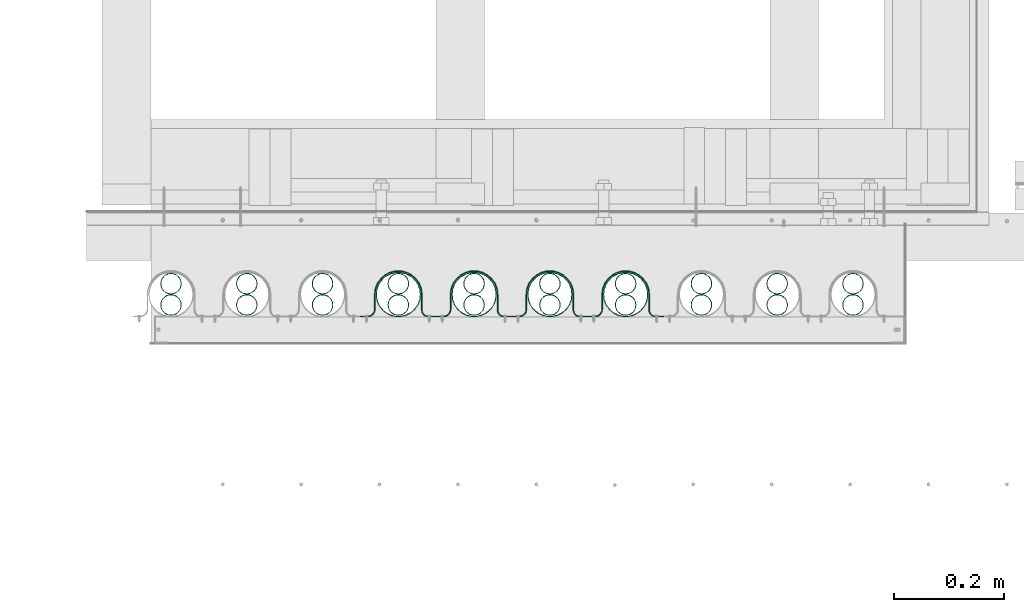
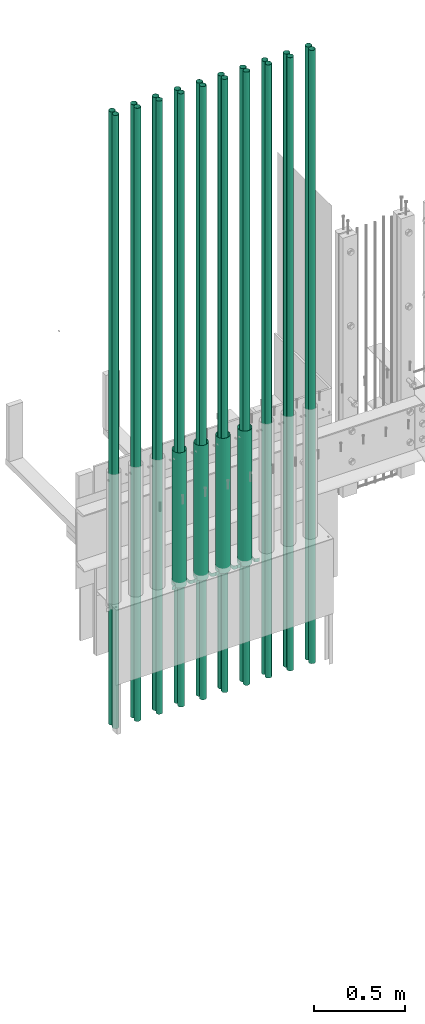
# One storey, part 6 of 44: 14 pipe fittings, 4 valves.
"""IFC4 building model written with IfcOpenShell, lengths in feet."""

from ifc_helpers import new_model, entity, si_unit, converted_unit, derived_unit, direction, frame, frame_2d, origin, origin_2d_with_axis, place, context, subcontext, project, spatial, polyline, circle_curve, parameter, trimmed, segment, composite_curve, hollow_circle, outline, extrude, source, transform, mapped, material, type_object, type_shapes, element, save


model = new_model("IFC4")

# Units and contexts
model_context = context("Model", 3, precision=0.0001, world=origin(), true_north=direction((6.12303176911189e-17, 1.0)))
body_context = subcontext(model_context, "Body", "Model", "MODEL_VIEW")
ifc_project = project(units=[converted_unit("LENGTHUNIT", "FOOT", entity("IfcRatioMeasure", 0.3048), si_unit("LENGTHUNIT", "METRE"), dimensions=[1, 0, 0, 0, 0, 0, 0]), converted_unit("AREAUNIT", "SQUARE FOOT", entity("IfcRatioMeasure", 0.09290304), si_unit("AREAUNIT", "SQUARE_METRE"), dimensions=[2, 0, 0, 0, 0, 0, 0]), converted_unit("VOLUMEUNIT", "CUBIC FOOT", entity("IfcRatioMeasure", 0.028316846592), si_unit("VOLUMEUNIT", "CUBIC_METRE"), dimensions=[3, 0, 0, 0, 0, 0, 0]), converted_unit("PLANEANGLEUNIT", "DEGREE", entity("IfcRatioMeasure", 0.0174532925199433), si_unit("PLANEANGLEUNIT", "RADIAN"), dimensions=[0, 0, 0, 0, 0, 0, 0]), si_unit("MASSUNIT", "GRAM", prefix="KILO"), derived_unit("MASSDENSITYUNIT", [(si_unit("MASSUNIT", "GRAM", prefix="KILO"), 1), (si_unit("LENGTHUNIT", "METRE"), -3)]), derived_unit("MOMENTOFINERTIAUNIT", [(si_unit("LENGTHUNIT", "METRE"), 4)]), si_unit("TIMEUNIT", "SECOND"), si_unit("FREQUENCYUNIT", "HERTZ"), si_unit("THERMODYNAMICTEMPERATUREUNIT", "DEGREE_CELSIUS"), derived_unit("THERMALTRANSMITTANCEUNIT", [(si_unit("MASSUNIT", "GRAM", prefix="KILO"), 1), (si_unit("THERMODYNAMICTEMPERATUREUNIT", "KELVIN"), -1), (si_unit("TIMEUNIT", "SECOND"), -3)]), derived_unit("VOLUMETRICFLOWRATEUNIT", [(si_unit("LENGTHUNIT", "METRE"), 3), (si_unit("TIMEUNIT", "SECOND"), -1)]), si_unit("ELECTRICCURRENTUNIT", "AMPERE"), si_unit("ELECTRICVOLTAGEUNIT", "VOLT"), si_unit("POWERUNIT", "WATT"), si_unit("FORCEUNIT", "NEWTON"), si_unit("ILLUMINANCEUNIT", "LUX"), si_unit("LUMINOUSFLUXUNIT", "LUMEN"), si_unit("LUMINOUSINTENSITYUNIT", "CANDELA"), derived_unit("USERDEFINED", [(si_unit("MASSUNIT", "GRAM", prefix="KILO"), -1), (si_unit("LENGTHUNIT", "METRE"), -2), (si_unit("TIMEUNIT", "SECOND"), 3), (si_unit("LUMINOUSFLUXUNIT", "LUMEN"), 1)]), derived_unit("LINEARVELOCITYUNIT", [(si_unit("LENGTHUNIT", "METRE"), 1), (si_unit("TIMEUNIT", "SECOND"), -1)]), si_unit("PRESSUREUNIT", "PASCAL"), derived_unit("USERDEFINED", [(si_unit("LENGTHUNIT", "METRE"), -2), (si_unit("MASSUNIT", "GRAM", prefix="KILO"), 1), (si_unit("TIMEUNIT", "SECOND"), -2)]), derived_unit("LINEARFORCEUNIT", [(si_unit("MASSUNIT", "GRAM", prefix="KILO"), 1), (si_unit("LENGTHUNIT", "METRE"), 1), (si_unit("TIMEUNIT", "SECOND"), -2), (si_unit("LENGTHUNIT", "METRE"), -1)]), derived_unit("PLANARFORCEUNIT", [(si_unit("MASSUNIT", "GRAM", prefix="KILO"), 1), (si_unit("LENGTHUNIT", "METRE"), 1), (si_unit("TIMEUNIT", "SECOND"), -2), (si_unit("LENGTHUNIT", "METRE"), -2)])], contexts=[model_context])

# Site, building, storey
site_placement = place(None, origin())
site = spatial("IfcSite", under=ifc_project, at=site_placement, CompositionType="ELEMENT")
building_placement = place(site_placement, origin())
building = spatial("IfcBuilding", under=site, at=building_placement, CompositionType="ELEMENT")
storey_placement = place(building_placement, origin())
storey = spatial("IfcBuildingStorey", under=building, at=storey_placement, CompositionType="ELEMENT", Elevation=0.0)

# Pipe fittings
ifc_material_1 = material(Name="MINI SPLIT LINE SETS", Category="Materials")
pipe_fitting_type_1 = type_object("IfcPipeFittingType", Name="Pipe:Pipe", PredefinedType="NOTDEFINED", material=ifc_material_1)
shared_shape_1 = source(origin(), body_context, "Body", "SweptSolid", [
    extrude(hollow_circle(Radius=0.0625, WallThickness=0.00260416666666666, at=origin_2d_with_axis()), frame((0.0677338327950565, 0.195337999461667, 0.0)), (0.0, 0.0, 1.0), 13.4850384539234),
    extrude(hollow_circle(Radius=0.0625, WallThickness=0.00260416666666666, at=origin_2d_with_axis()), frame((0.0677338327950565, 0.0677338327949997, 0.0)), (0.0, 0.0, 1.0), 13.4850384539234),
])
type_shapes(pipe_fitting_type_1, [shared_shape_1])
pipe_fitting_1_placement = place(storey_placement, frame((1491.01565957711, 4.12033855704859, 5.26036370303956)))
element("IfcPipeFitting", 1, at=pipe_fitting_1_placement, inside=storey, type_object=pipe_fitting_type_1, material=ifc_material_1, Name="Pipe:Pipe", ObjectType="Pipe:Pipe", PredefinedType="NOTDEFINED", context=body_context, shape_type="MappedRepresentation", body=[
    mapped(shared_shape_1, transform((0.0, 0.0, 0.0), scale=1.0)),
])
pipe_fitting_type_2 = type_object("IfcPipeFittingType", Name="Pipe2:Pipe", PredefinedType="NOTDEFINED", material=ifc_material_1)
shared_shape_2 = source(origin(), body_context, "Body", "SweptSolid", [
    extrude(hollow_circle(Radius=0.0625, WallThickness=0.00260416666666666, at=origin_2d_with_axis()), frame((0.0677338327950565, 0.195337999461667, 0.0)), (0.0, 0.0, 1.0), 13.4850384539234),
    extrude(hollow_circle(Radius=0.0625, WallThickness=0.00260416666666666, at=origin_2d_with_axis()), frame((0.0677338327950565, 0.0677338327949997, 0.0)), (0.0, 0.0, 1.0), 13.4850384539234),
])
type_shapes(pipe_fitting_type_2, [shared_shape_2])
pipe_fitting_2_placement = place(storey_placement, frame((1491.46955171939, 4.12033855704859, 5.26036370303956)))
element("IfcPipeFitting", 2, at=pipe_fitting_2_placement, inside=storey, type_object=pipe_fitting_type_2, material=ifc_material_1, Name="Pipe2:Pipe", ObjectType="Pipe2:Pipe", PredefinedType="NOTDEFINED", context=body_context, shape_type="MappedRepresentation", body=[
    mapped(shared_shape_2, transform((0.0, 0.0, 0.0), scale=1.0)),
])
pipe_fitting_type_3 = type_object("IfcPipeFittingType", Name="Pipe4:Pipe", PredefinedType="NOTDEFINED", material=ifc_material_1)
shared_shape_3 = source(origin(), body_context, "Body", "SweptSolid", [
    extrude(hollow_circle(Radius=0.0625, WallThickness=0.00260416666666666, at=origin_2d_with_axis()), frame((0.0677338327950565, 0.195337999461667, 0.0)), (0.0, 0.0, 1.0), 13.4850384539234),
    extrude(hollow_circle(Radius=0.0625, WallThickness=0.00260416666666666, at=origin_2d_with_axis()), frame((0.0677338327950565, 0.0677338327949997, 0.0)), (0.0, 0.0, 1.0), 13.4850384539234),
])
type_shapes(pipe_fitting_type_3, [shared_shape_3])
pipe_fitting_3_placement = place(storey_placement, frame((1490.56176743483, 4.1203385570486, 5.26036370303955)))
element("IfcPipeFitting", 3, at=pipe_fitting_3_placement, inside=storey, type_object=pipe_fitting_type_3, material=ifc_material_1, Name="Pipe4:Pipe", ObjectType="Pipe4:Pipe", PredefinedType="NOTDEFINED", context=body_context, shape_type="MappedRepresentation", body=[
    mapped(shared_shape_3, transform((0.0, 0.0, 0.0), scale=1.0)),
])
pipe_fitting_type_4 = type_object("IfcPipeFittingType", Name="Pipe6:Pipe", PredefinedType="NOTDEFINED", material=ifc_material_1)
shared_shape_4 = source(origin(), body_context, "Body", "SweptSolid", [
    extrude(hollow_circle(Radius=0.0625, WallThickness=0.00260416666666666, at=origin_2d_with_axis()), frame((0.0677338327950565, 0.195337999461667, 0.0)), (0.0, 0.0, 1.0), 13.4850384539234),
    extrude(hollow_circle(Radius=0.0625, WallThickness=0.00260416666666666, at=origin_2d_with_axis()), frame((0.0677338327950565, 0.0677338327949997, 0.0)), (0.0, 0.0, 1.0), 13.4850384539234),
])
type_shapes(pipe_fitting_type_4, [shared_shape_4])
pipe_fitting_4_placement = place(storey_placement, frame((1490.10787529256, 4.1203385570486, 5.26036370303955)))
element("IfcPipeFitting", 4, at=pipe_fitting_4_placement, inside=storey, type_object=pipe_fitting_type_4, material=ifc_material_1, Name="Pipe6:Pipe", ObjectType="Pipe6:Pipe", PredefinedType="NOTDEFINED", context=body_context, shape_type="MappedRepresentation", body=[
    mapped(shared_shape_4, transform((0.0, 0.0, 0.0), scale=1.0)),
])
ifc_material_2 = material(Name="GALV. PIPE", Category="Materials")
pipe_fitting_type_5 = type_object("IfcPipeFittingType", Name="Pipe7:Pipe", PredefinedType="NOTDEFINED", material=ifc_material_2)
shared_shape_5 = source(origin(), body_context, "Body", "SweptSolid", [
    extrude(hollow_circle(Radius=0.133196488133789, WallThickness=0.00260416666666666, at=frame_2d((2.91529109135044e-30, -8.88178419700125e-16), x_axis=(1.0, 0.0))), frame((0.138430320928819, 0.138430320928789, 0.0)), (0.0, 0.0, 1.0), 2.97420597925747),
])
type_shapes(pipe_fitting_type_5, [shared_shape_5])
pipe_fitting_5_placement = place(storey_placement, frame((1490.03717880442, 4.11247536199349, 7.88838525934748)))
element("IfcPipeFitting", 5, at=pipe_fitting_5_placement, inside=storey, type_object=pipe_fitting_type_5, material=ifc_material_2, Name="Pipe7:Pipe", ObjectType="Pipe7:Pipe", PredefinedType="NOTDEFINED", context=body_context, shape_type="MappedRepresentation", body=[
    mapped(shared_shape_5, transform((0.0, 0.0, 0.0), scale=1.0)),
])

# Valve
ifc_material_3 = material(Name="GALV. U BRACKET AT GALV. PIPE", Category="Materials")
valve_type_1 = type_object("IfcValveType", Name="U BRACKET8:U BRACKET", PredefinedType="NOTDEFINED", material=ifc_material_3)
shared_shape_6 = source(origin(), body_context, "Body", "SweptSolid", [
    extrude(outline(composite_curve([segment(polyline([(0.0407648216664178, -0.226295029472567), (0.0459731549997509, -0.226295029472567)]), True, "CONTINUOUS"), segment(polyline([(0.0459731549997509, -0.226295029472567), (0.0459731549997509, -0.184628362805825)]), True, "CONTINUOUS"), segment(trimmed(circle_curve(frame_2d((-0.000901845000249146, -0.184628362805825), x_axis=(0.0, 1.0)), 0.046875), [parameter(270.0)], [parameter(2.03555499613665e-13)], True, "PARAMETER"), True, "CONTINUOUS"), segment(polyline([(-0.000901845000249146, -0.137753362805825), (-0.0884402983327055, -0.137753362805825)]), True, "CONTINUOUS"), segment(trimmed(circle_curve(frame_2d((-0.0884402983327037, 0.000651041666515084), x_axis=(0.0, 1.0)), 0.138404404472415), [parameter(2.03555499613665e-13)], [parameter(180.0)], True, "PARAMETER"), False, "CONTINUOUS"), segment(polyline([(-0.0884402983327037, 0.139055446138855), (0.00430648833316294, 0.139055446138855)]), True, "CONTINUOUS"), segment(trimmed(circle_curve(frame_2d((0.00430648833316294, 0.180722112805597), x_axis=(0.0, 1.0)), 0.0416666666666667), [parameter(180.0)], [parameter(270.0)], True, "PARAMETER"), True, "CONTINUOUS"), segment(polyline([(0.0459731549998299, 0.180722112805597), (0.0459731549998308, 0.227597112805597)]), True, "CONTINUOUS"), segment(polyline([(0.0459731549998308, 0.227597112805597), (0.0407648216664969, 0.227597112805597)]), True, "CONTINUOUS"), segment(polyline([(0.0407648216664969, 0.227597112805597), (0.0407648216664969, 0.180722112805597)]), True, "CONTINUOUS"), segment(trimmed(circle_curve(frame_2d((0.00430648833316294, 0.180722112805597), x_axis=(0.0, 1.0)), 0.0364583333333333), [parameter(180.0)], [parameter(270.0)], True, "PARAMETER"), False, "CONTINUOUS"), segment(polyline([(0.00430648833316294, 0.14426377947234), (-0.0884402983327028, 0.14426377947234)]), True, "CONTINUOUS"), segment(trimmed(circle_curve(frame_2d((-0.0884402983327037, 0.000651041666515084), x_axis=(0.0, 1.0)), 0.143612737805749), [parameter(360.0)], [parameter(180.0)], True, "PARAMETER"), True, "CONTINUOUS"), segment(polyline([(-0.0884402983327055, -0.142961696139309), (-0.000901845000249146, -0.142961696139309)]), True, "CONTINUOUS"), segment(trimmed(circle_curve(frame_2d((-0.000901845000249146, -0.184628362805825), x_axis=(0.0, 1.0)), 0.0416666666666667), [parameter(270.0)], [parameter(2.03555499613665e-13)], True, "PARAMETER"), False, "CONTINUOUS"), segment(polyline([(0.0407648216664178, -0.184628362805825), (0.0407648216664178, -0.226295029472567)]), True, "CONTINUOUS")], self_intersect=False)), frame((0.226295029472567, 0.0512069877948296, 0.0), z_axis=(0.0, 0.0, 1.0), x_axis=(0.0, -1.0, 0.0)), (0.0, 0.0, 1.0), 0.078003864882298),
])
type_shapes(valve_type_1, [shared_shape_6])
valve_1_placement = place(storey_placement, frame((1489.94866305421, 4.11092510371607, 7.91059739384998)))
element("IfcValve", 6, at=valve_1_placement, inside=storey, type_object=valve_type_1, material=ifc_material_3, Name="U BRACKET8:U BRACKET", ObjectType="U BRACKET8:U BRACKET", PredefinedType="NOTDEFINED", context=body_context, shape_type="MappedRepresentation", body=[
    mapped(shared_shape_6, transform((0.0, 0.0, 0.0), scale=1.0)),
])

# Pipe fittings
pipe_fitting_type_6 = type_object("IfcPipeFittingType", Name="Pipe8:Pipe", PredefinedType="NOTDEFINED", material=ifc_material_1)
shared_shape_7 = source(origin(), body_context, "Body", "SweptSolid", [
    extrude(hollow_circle(Radius=0.0625, WallThickness=0.00260416666666666, at=origin_2d_with_axis()), frame((0.0677338327950565, 0.195337999461667, 0.0)), (0.0, 0.0, 1.0), 13.4850384539234),
    extrude(hollow_circle(Radius=0.0625, WallThickness=0.00260416666666666, at=origin_2d_with_axis()), frame((0.0677338327950565, 0.0677338327949997, 0.0)), (0.0, 0.0, 1.0), 13.4850384539234),
])
type_shapes(pipe_fitting_type_6, [shared_shape_7])
pipe_fitting_6_placement = place(storey_placement, frame((1489.65398315028, 4.1203385570486, 5.26036370303955)))
element("IfcPipeFitting", 7, at=pipe_fitting_6_placement, inside=storey, type_object=pipe_fitting_type_6, material=ifc_material_1, Name="Pipe8:Pipe", ObjectType="Pipe8:Pipe", PredefinedType="NOTDEFINED", context=body_context, shape_type="MappedRepresentation", body=[
    mapped(shared_shape_7, transform((0.0, 0.0, 0.0), scale=1.0)),
])
pipe_fitting_type_7 = type_object("IfcPipeFittingType", Name="Pipe9:Pipe", PredefinedType="NOTDEFINED", material=ifc_material_2)
shared_shape_8 = source(origin(), body_context, "Body", "SweptSolid", [
    extrude(hollow_circle(Radius=0.133196488133789, WallThickness=0.00260416666666666, at=frame_2d((2.91529109135044e-30, -8.88178419700125e-16), x_axis=(1.0, 0.0))), frame((0.138430320928819, 0.138430320928789, 0.0)), (0.0, 0.0, 1.0), 2.97420597925747),
])
type_shapes(pipe_fitting_type_7, [shared_shape_8])
pipe_fitting_7_placement = place(storey_placement, frame((1489.58328666214, 4.11247536199349, 7.88838525934748)))
element("IfcPipeFitting", 8, at=pipe_fitting_7_placement, inside=storey, type_object=pipe_fitting_type_7, material=ifc_material_2, Name="Pipe9:Pipe", ObjectType="Pipe9:Pipe", PredefinedType="NOTDEFINED", context=body_context, shape_type="MappedRepresentation", body=[
    mapped(shared_shape_8, transform((0.0, 0.0, 0.0), scale=1.0)),
])

# Valve
valve_type_2 = type_object("IfcValveType", Name="U BRACKET10:U BRACKET", PredefinedType="NOTDEFINED", material=ifc_material_3)
shared_shape_9 = source(origin(), body_context, "Body", "SweptSolid", [
    extrude(outline(composite_curve([segment(polyline([(0.0407648216664178, -0.226295029472567), (0.0459731549997509, -0.226295029472567)]), True, "CONTINUOUS"), segment(polyline([(0.0459731549997509, -0.226295029472567), (0.0459731549997509, -0.184628362805825)]), True, "CONTINUOUS"), segment(trimmed(circle_curve(frame_2d((-0.000901845000249146, -0.184628362805825), x_axis=(0.0, 1.0)), 0.046875), [parameter(270.0)], [parameter(2.03555499613665e-13)], True, "PARAMETER"), True, "CONTINUOUS"), segment(polyline([(-0.000901845000249146, -0.137753362805825), (-0.0884402983327055, -0.137753362805825)]), True, "CONTINUOUS"), segment(trimmed(circle_curve(frame_2d((-0.0884402983327037, 0.000651041666515084), x_axis=(0.0, 1.0)), 0.138404404472415), [parameter(2.03555499613665e-13)], [parameter(180.0)], True, "PARAMETER"), False, "CONTINUOUS"), segment(polyline([(-0.0884402983327037, 0.139055446138855), (0.00430648833316294, 0.139055446138855)]), True, "CONTINUOUS"), segment(trimmed(circle_curve(frame_2d((0.00430648833316294, 0.180722112805597), x_axis=(0.0, 1.0)), 0.0416666666666667), [parameter(180.0)], [parameter(270.0)], True, "PARAMETER"), True, "CONTINUOUS"), segment(polyline([(0.0459731549998299, 0.180722112805597), (0.0459731549998308, 0.227597112805597)]), True, "CONTINUOUS"), segment(polyline([(0.0459731549998308, 0.227597112805597), (0.0407648216664969, 0.227597112805597)]), True, "CONTINUOUS"), segment(polyline([(0.0407648216664969, 0.227597112805597), (0.0407648216664969, 0.180722112805597)]), True, "CONTINUOUS"), segment(trimmed(circle_curve(frame_2d((0.00430648833316294, 0.180722112805597), x_axis=(0.0, 1.0)), 0.0364583333333333), [parameter(180.0)], [parameter(270.0)], True, "PARAMETER"), False, "CONTINUOUS"), segment(polyline([(0.00430648833316294, 0.14426377947234), (-0.0884402983327028, 0.14426377947234)]), True, "CONTINUOUS"), segment(trimmed(circle_curve(frame_2d((-0.0884402983327037, 0.000651041666515084), x_axis=(0.0, 1.0)), 0.143612737805749), [parameter(360.0)], [parameter(180.0)], True, "PARAMETER"), True, "CONTINUOUS"), segment(polyline([(-0.0884402983327055, -0.142961696139309), (-0.000901845000249146, -0.142961696139309)]), True, "CONTINUOUS"), segment(trimmed(circle_curve(frame_2d((-0.000901845000249146, -0.184628362805825), x_axis=(0.0, 1.0)), 0.0416666666666667), [parameter(270.0)], [parameter(2.03555499613665e-13)], True, "PARAMETER"), False, "CONTINUOUS"), segment(polyline([(0.0407648216664178, -0.184628362805825), (0.0407648216664178, -0.226295029472567)]), True, "CONTINUOUS")], self_intersect=False)), frame((0.226295029472567, 0.0512069877948296, 0.0), z_axis=(0.0, 0.0, 1.0), x_axis=(0.0, -1.0, 0.0)), (0.0, 0.0, 1.0), 0.078003864882298),
])
type_shapes(valve_type_2, [shared_shape_9])
valve_2_placement = place(storey_placement, frame((1489.49477091193, 4.11092510371607, 7.91059739384998)))
element("IfcValve", 9, at=valve_2_placement, inside=storey, type_object=valve_type_2, material=ifc_material_3, Name="U BRACKET10:U BRACKET", ObjectType="U BRACKET10:U BRACKET", PredefinedType="NOTDEFINED", context=body_context, shape_type="MappedRepresentation", body=[
    mapped(shared_shape_9, transform((0.0, 0.0, 0.0), scale=1.0)),
])

# Pipe fittings
pipe_fitting_type_8 = type_object("IfcPipeFittingType", Name="Pipe10:Pipe", PredefinedType="NOTDEFINED", material=ifc_material_1)
shared_shape_10 = source(origin(), body_context, "Body", "SweptSolid", [
    extrude(hollow_circle(Radius=0.0625, WallThickness=0.00260416666666666, at=origin_2d_with_axis()), frame((0.0677338327950565, 0.195337999461667, 0.0)), (0.0, 0.0, 1.0), 13.4850384539234),
    extrude(hollow_circle(Radius=0.0625, WallThickness=0.00260416666666666, at=origin_2d_with_axis()), frame((0.0677338327950565, 0.0677338327949997, 0.0)), (0.0, 0.0, 1.0), 13.4850384539234),
])
type_shapes(pipe_fitting_type_8, [shared_shape_10])
pipe_fitting_8_placement = place(storey_placement, frame((1489.200091008, 4.1203385570486, 5.26036370303955)))
element("IfcPipeFitting", 10, at=pipe_fitting_8_placement, inside=storey, type_object=pipe_fitting_type_8, material=ifc_material_1, Name="Pipe10:Pipe", ObjectType="Pipe10:Pipe", PredefinedType="NOTDEFINED", context=body_context, shape_type="MappedRepresentation", body=[
    mapped(shared_shape_10, transform((0.0, 0.0, 0.0), scale=1.0)),
])
pipe_fitting_type_9 = type_object("IfcPipeFittingType", Name="Pipe11:Pipe", PredefinedType="NOTDEFINED", material=ifc_material_2)
shared_shape_11 = source(origin(), body_context, "Body", "SweptSolid", [
    extrude(hollow_circle(Radius=0.133196488133789, WallThickness=0.00260416666666666, at=frame_2d((2.91529109135044e-30, -8.88178419700125e-16), x_axis=(1.0, 0.0))), frame((0.138430320928819, 0.138430320928789, 0.0)), (0.0, 0.0, 1.0), 2.97420597925747),
])
type_shapes(pipe_fitting_type_9, [shared_shape_11])
pipe_fitting_9_placement = place(storey_placement, frame((1489.12939451987, 4.1124753619935, 7.88838525934748)))
element("IfcPipeFitting", 11, at=pipe_fitting_9_placement, inside=storey, type_object=pipe_fitting_type_9, material=ifc_material_2, Name="Pipe11:Pipe", ObjectType="Pipe11:Pipe", PredefinedType="NOTDEFINED", context=body_context, shape_type="MappedRepresentation", body=[
    mapped(shared_shape_11, transform((0.0, 0.0, 0.0), scale=1.0)),
])

# Valve
valve_type_3 = type_object("IfcValveType", Name="U BRACKET12:U BRACKET", PredefinedType="NOTDEFINED", material=ifc_material_3)
shared_shape_12 = source(origin(), body_context, "Body", "SweptSolid", [
    extrude(outline(composite_curve([segment(polyline([(0.0407648216664178, -0.226295029472567), (0.0459731549997509, -0.226295029472567)]), True, "CONTINUOUS"), segment(polyline([(0.0459731549997509, -0.226295029472567), (0.0459731549997509, -0.184628362805825)]), True, "CONTINUOUS"), segment(trimmed(circle_curve(frame_2d((-0.000901845000249146, -0.184628362805825), x_axis=(0.0, 1.0)), 0.046875), [parameter(270.0)], [parameter(2.03555499613665e-13)], True, "PARAMETER"), True, "CONTINUOUS"), segment(polyline([(-0.000901845000249146, -0.137753362805825), (-0.0884402983327055, -0.137753362805825)]), True, "CONTINUOUS"), segment(trimmed(circle_curve(frame_2d((-0.0884402983327037, 0.000651041666515084), x_axis=(0.0, 1.0)), 0.138404404472415), [parameter(2.03555499613665e-13)], [parameter(180.0)], True, "PARAMETER"), False, "CONTINUOUS"), segment(polyline([(-0.0884402983327037, 0.139055446138855), (0.00430648833316294, 0.139055446138855)]), True, "CONTINUOUS"), segment(trimmed(circle_curve(frame_2d((0.00430648833316294, 0.180722112805597), x_axis=(0.0, 1.0)), 0.0416666666666667), [parameter(180.0)], [parameter(270.0)], True, "PARAMETER"), True, "CONTINUOUS"), segment(polyline([(0.0459731549998299, 0.180722112805597), (0.0459731549998308, 0.227597112805597)]), True, "CONTINUOUS"), segment(polyline([(0.0459731549998308, 0.227597112805597), (0.0407648216664969, 0.227597112805597)]), True, "CONTINUOUS"), segment(polyline([(0.0407648216664969, 0.227597112805597), (0.0407648216664969, 0.180722112805597)]), True, "CONTINUOUS"), segment(trimmed(circle_curve(frame_2d((0.00430648833316294, 0.180722112805597), x_axis=(0.0, 1.0)), 0.0364583333333333), [parameter(180.0)], [parameter(270.0)], True, "PARAMETER"), False, "CONTINUOUS"), segment(polyline([(0.00430648833316294, 0.14426377947234), (-0.0884402983327028, 0.14426377947234)]), True, "CONTINUOUS"), segment(trimmed(circle_curve(frame_2d((-0.0884402983327037, 0.000651041666515084), x_axis=(0.0, 1.0)), 0.143612737805749), [parameter(360.0)], [parameter(180.0)], True, "PARAMETER"), True, "CONTINUOUS"), segment(polyline([(-0.0884402983327055, -0.142961696139309), (-0.000901845000249146, -0.142961696139309)]), True, "CONTINUOUS"), segment(trimmed(circle_curve(frame_2d((-0.000901845000249146, -0.184628362805825), x_axis=(0.0, 1.0)), 0.0416666666666667), [parameter(270.0)], [parameter(2.03555499613665e-13)], True, "PARAMETER"), False, "CONTINUOUS"), segment(polyline([(0.0407648216664178, -0.184628362805825), (0.0407648216664178, -0.226295029472567)]), True, "CONTINUOUS")], self_intersect=False)), frame((0.226295029472567, 0.0512069877948296, 0.0), z_axis=(0.0, 0.0, 1.0), x_axis=(0.0, -1.0, 0.0)), (0.0, 0.0, 1.0), 0.0780038648822972),
])
type_shapes(valve_type_3, [shared_shape_12])
valve_3_placement = place(storey_placement, frame((1489.04087876966, 4.11092510371607, 7.91059739384998)))
element("IfcValve", 12, at=valve_3_placement, inside=storey, type_object=valve_type_3, material=ifc_material_3, Name="U BRACKET12:U BRACKET", ObjectType="U BRACKET12:U BRACKET", PredefinedType="NOTDEFINED", context=body_context, shape_type="MappedRepresentation", body=[
    mapped(shared_shape_12, transform((0.0, 0.0, 0.0), scale=1.0)),
])

# Pipe fittings
pipe_fitting_type_10 = type_object("IfcPipeFittingType", Name="Pipe12:Pipe", PredefinedType="NOTDEFINED", material=ifc_material_1)
shared_shape_13 = source(origin(), body_context, "Body", "SweptSolid", [
    extrude(hollow_circle(Radius=0.0625, WallThickness=0.00260416666666666, at=origin_2d_with_axis()), frame((0.0677338327950565, 0.195337999461667, 0.0)), (0.0, 0.0, 1.0), 13.4850384539234),
    extrude(hollow_circle(Radius=0.0625, WallThickness=0.00260416666666666, at=origin_2d_with_axis()), frame((0.0677338327950565, 0.0677338327949997, 0.0)), (0.0, 0.0, 1.0), 13.4850384539234),
])
type_shapes(pipe_fitting_type_10, [shared_shape_13])
pipe_fitting_10_placement = place(storey_placement, frame((1488.74619886572, 4.12033855704861, 5.26036370303955)))
element("IfcPipeFitting", 13, at=pipe_fitting_10_placement, inside=storey, type_object=pipe_fitting_type_10, material=ifc_material_1, Name="Pipe12:Pipe", ObjectType="Pipe12:Pipe", PredefinedType="NOTDEFINED", context=body_context, shape_type="MappedRepresentation", body=[
    mapped(shared_shape_13, transform((0.0, 0.0, 0.0), scale=1.0)),
])
pipe_fitting_type_11 = type_object("IfcPipeFittingType", Name="Pipe13:Pipe", PredefinedType="NOTDEFINED", material=ifc_material_2)
shared_shape_14 = source(origin(), body_context, "Body", "SweptSolid", [
    extrude(hollow_circle(Radius=0.133196488133789, WallThickness=0.00260416666666666, at=frame_2d((2.91529109135044e-30, -8.88178419700125e-16), x_axis=(1.0, 0.0))), frame((0.138430320928819, 0.138430320928789, 0.0)), (0.0, 0.0, 1.0), 2.97420597925747),
])
type_shapes(pipe_fitting_type_11, [shared_shape_14])
pipe_fitting_11_placement = place(storey_placement, frame((1488.67550237759, 4.1124753619935, 7.88838525934748)))
element("IfcPipeFitting", 14, at=pipe_fitting_11_placement, inside=storey, type_object=pipe_fitting_type_11, material=ifc_material_2, Name="Pipe13:Pipe", ObjectType="Pipe13:Pipe", PredefinedType="NOTDEFINED", context=body_context, shape_type="MappedRepresentation", body=[
    mapped(shared_shape_14, transform((0.0, 0.0, 0.0), scale=1.0)),
])

# Valve
valve_type_4 = type_object("IfcValveType", Name="U BRACKET14:U BRACKET", PredefinedType="NOTDEFINED", material=ifc_material_3)
shared_shape_15 = source(origin(), body_context, "Body", "SweptSolid", [
    extrude(outline(composite_curve([segment(polyline([(0.0407648216664178, -0.226295029472567), (0.0459731549997509, -0.226295029472567)]), True, "CONTINUOUS"), segment(polyline([(0.0459731549997509, -0.226295029472567), (0.0459731549997509, -0.184628362805825)]), True, "CONTINUOUS"), segment(trimmed(circle_curve(frame_2d((-0.000901845000249146, -0.184628362805825), x_axis=(0.0, 1.0)), 0.046875), [parameter(270.0)], [parameter(2.03555499613665e-13)], True, "PARAMETER"), True, "CONTINUOUS"), segment(polyline([(-0.000901845000249146, -0.137753362805825), (-0.0884402983327055, -0.137753362805825)]), True, "CONTINUOUS"), segment(trimmed(circle_curve(frame_2d((-0.0884402983327037, 0.000651041666515084), x_axis=(0.0, 1.0)), 0.138404404472415), [parameter(2.03555499613665e-13)], [parameter(180.0)], True, "PARAMETER"), False, "CONTINUOUS"), segment(polyline([(-0.0884402983327037, 0.139055446138855), (0.00430648833316294, 0.139055446138855)]), True, "CONTINUOUS"), segment(trimmed(circle_curve(frame_2d((0.00430648833316294, 0.180722112805597), x_axis=(0.0, 1.0)), 0.0416666666666667), [parameter(180.0)], [parameter(270.0)], True, "PARAMETER"), True, "CONTINUOUS"), segment(polyline([(0.0459731549998299, 0.180722112805597), (0.0459731549998308, 0.227597112805597)]), True, "CONTINUOUS"), segment(polyline([(0.0459731549998308, 0.227597112805597), (0.0407648216664969, 0.227597112805597)]), True, "CONTINUOUS"), segment(polyline([(0.0407648216664969, 0.227597112805597), (0.0407648216664969, 0.180722112805597)]), True, "CONTINUOUS"), segment(trimmed(circle_curve(frame_2d((0.00430648833316294, 0.180722112805597), x_axis=(0.0, 1.0)), 0.0364583333333333), [parameter(180.0)], [parameter(270.0)], True, "PARAMETER"), False, "CONTINUOUS"), segment(polyline([(0.00430648833316294, 0.14426377947234), (-0.0884402983327028, 0.14426377947234)]), True, "CONTINUOUS"), segment(trimmed(circle_curve(frame_2d((-0.0884402983327037, 0.000651041666515084), x_axis=(0.0, 1.0)), 0.143612737805749), [parameter(360.0)], [parameter(180.0)], True, "PARAMETER"), True, "CONTINUOUS"), segment(polyline([(-0.0884402983327055, -0.142961696139309), (-0.000901845000249146, -0.142961696139309)]), True, "CONTINUOUS"), segment(trimmed(circle_curve(frame_2d((-0.000901845000249146, -0.184628362805825), x_axis=(0.0, 1.0)), 0.0416666666666667), [parameter(270.0)], [parameter(2.03555499613665e-13)], True, "PARAMETER"), False, "CONTINUOUS"), segment(polyline([(0.0407648216664178, -0.184628362805825), (0.0407648216664178, -0.226295029472567)]), True, "CONTINUOUS")], self_intersect=False)), frame((0.226295029472567, 0.0512069877948296, 0.0), z_axis=(0.0, 0.0, 1.0), x_axis=(0.0, -1.0, 0.0)), (0.0, 0.0, 1.0), 0.0780038648822963),
])
type_shapes(valve_type_4, [shared_shape_15])
valve_4_placement = place(storey_placement, frame((1488.58698662738, 4.11092510371607, 7.91059739384998)))
element("IfcValve", 15, at=valve_4_placement, inside=storey, type_object=valve_type_4, material=ifc_material_3, Name="U BRACKET14:U BRACKET", ObjectType="U BRACKET14:U BRACKET", PredefinedType="NOTDEFINED", context=body_context, shape_type="MappedRepresentation", body=[
    mapped(shared_shape_15, transform((0.0, 0.0, 0.0), scale=1.0)),
])

# Pipe fittings
pipe_fitting_type_12 = type_object("IfcPipeFittingType", Name="Pipe14:Pipe", PredefinedType="NOTDEFINED", material=ifc_material_1)
shared_shape_16 = source(origin(), body_context, "Body", "SweptSolid", [
    extrude(hollow_circle(Radius=0.0625, WallThickness=0.00260416666666666, at=origin_2d_with_axis()), frame((0.0677338327950565, 0.195337999461667, 0.0)), (0.0, 0.0, 1.0), 13.4850384539234),
    extrude(hollow_circle(Radius=0.0625, WallThickness=0.00260416666666666, at=origin_2d_with_axis()), frame((0.0677338327950565, 0.0677338327949997, 0.0)), (0.0, 0.0, 1.0), 13.4850384539234),
])
type_shapes(pipe_fitting_type_12, [shared_shape_16])
pipe_fitting_12_placement = place(storey_placement, frame((1488.29230672344, 4.12033855704861, 5.26036370303955)))
element("IfcPipeFitting", 16, at=pipe_fitting_12_placement, inside=storey, type_object=pipe_fitting_type_12, material=ifc_material_1, Name="Pipe14:Pipe", ObjectType="Pipe14:Pipe", PredefinedType="NOTDEFINED", context=body_context, shape_type="MappedRepresentation", body=[
    mapped(shared_shape_16, transform((0.0, 0.0, 0.0), scale=1.0)),
])
pipe_fitting_type_13 = type_object("IfcPipeFittingType", Name="Pipe16:Pipe", PredefinedType="NOTDEFINED", material=ifc_material_1)
shared_shape_17 = source(origin(), body_context, "Body", "SweptSolid", [
    extrude(hollow_circle(Radius=0.0625, WallThickness=0.00260416666666666, at=origin_2d_with_axis()), frame((0.0677338327950565, 0.195337999461667, 0.0)), (0.0, 0.0, 1.0), 13.4850384539234),
    extrude(hollow_circle(Radius=0.0625, WallThickness=0.00260416666666666, at=origin_2d_with_axis()), frame((0.0677338327950565, 0.0677338327949997, 0.0)), (0.0, 0.0, 1.0), 13.4850384539234),
])
type_shapes(pipe_fitting_type_13, [shared_shape_17])
pipe_fitting_13_placement = place(storey_placement, frame((1487.83841458116, 4.12033855704861, 5.26036370303954)))
element("IfcPipeFitting", 17, at=pipe_fitting_13_placement, inside=storey, type_object=pipe_fitting_type_13, material=ifc_material_1, Name="Pipe16:Pipe", ObjectType="Pipe16:Pipe", PredefinedType="NOTDEFINED", context=body_context, shape_type="MappedRepresentation", body=[
    mapped(shared_shape_17, transform((0.0, 0.0, 0.0), scale=1.0)),
])
pipe_fitting_type_14 = type_object("IfcPipeFittingType", Name="Pipe18:Pipe", PredefinedType="NOTDEFINED", material=ifc_material_1)
shared_shape_18 = source(origin(), body_context, "Body", "SweptSolid", [
    extrude(hollow_circle(Radius=0.0625, WallThickness=0.00260416666666666, at=origin_2d_with_axis()), frame((0.0677338327950565, 0.195337999461667, 0.0)), (0.0, 0.0, 1.0), 13.4850384539234),
    extrude(hollow_circle(Radius=0.0625, WallThickness=0.00260416666666666, at=origin_2d_with_axis()), frame((0.0677338327950565, 0.0677338327949997, 0.0)), (0.0, 0.0, 1.0), 13.4850384539234),
])
type_shapes(pipe_fitting_type_14, [shared_shape_18])
pipe_fitting_14_placement = place(storey_placement, frame((1487.38452243889, 4.12033855704861, 5.26036370303954)))
element("IfcPipeFitting", 18, at=pipe_fitting_14_placement, inside=storey, type_object=pipe_fitting_type_14, material=ifc_material_1, Name="Pipe18:Pipe", ObjectType="Pipe18:Pipe", PredefinedType="NOTDEFINED", context=body_context, shape_type="MappedRepresentation", body=[
    mapped(shared_shape_18, transform((0.0, 0.0, 0.0), scale=1.0)),
])

save(model, "model.ifc")
